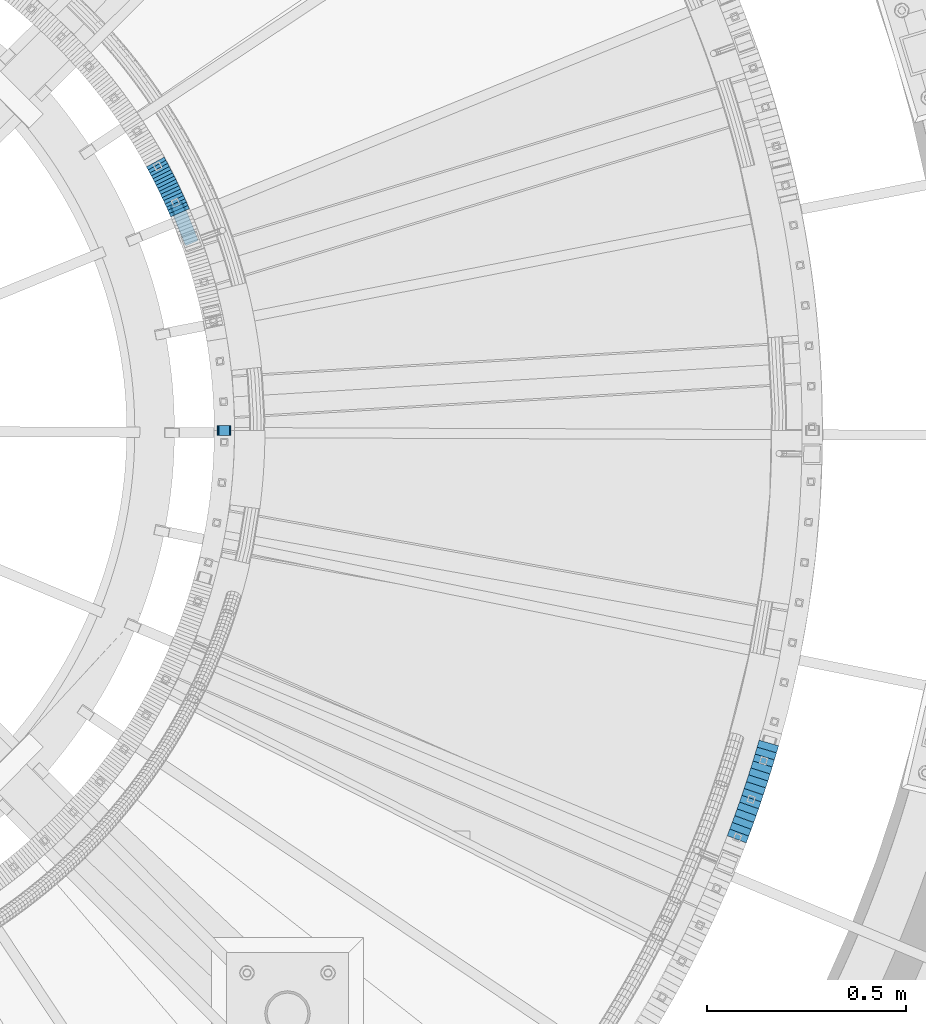
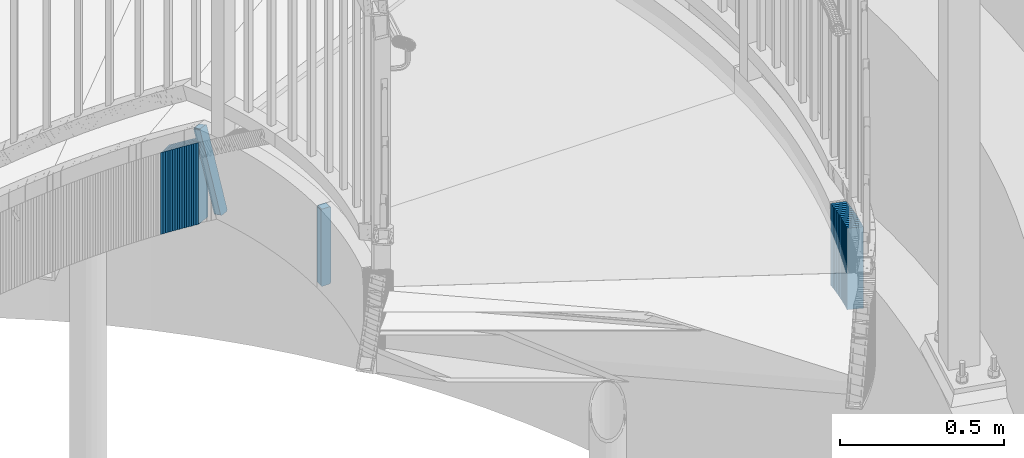
# One storey, part 909 of 975: 32 plates.
"""IFC2X3 building model written with IfcOpenShell, lengths in millimetres."""

from ifc_helpers import new_model, si_unit, frame, origin_with_axes, place, context, subcontext, project, spatial, faceted_brep, material, type_object, element, save


model = new_model("IFC2X3")

# Units and contexts
model_context = context("Model", 3, precision=1e-05, world=origin_with_axes())
body_context = subcontext(model_context, "Body", "Model", "MODEL_VIEW")
ifc_project = project(units=[si_unit("LENGTHUNIT", "METRE", prefix="MILLI"), si_unit("AREAUNIT", "SQUARE_METRE"), si_unit("VOLUMEUNIT", "CUBIC_METRE"), si_unit("MASSUNIT", "GRAM", prefix="KILO"), si_unit("TIMEUNIT", "SECOND"), si_unit("PLANEANGLEUNIT", "RADIAN"), si_unit("SOLIDANGLEUNIT", "STERADIAN"), si_unit("THERMODYNAMICTEMPERATUREUNIT", "DEGREE_CELSIUS"), si_unit("LUMINOUSINTENSITYUNIT", "LUMEN")], contexts=[model_context])

# Site, building, storey
site_placement = place(None, origin_with_axes())
site = spatial("IfcSite", under=ifc_project, at=site_placement, CompositionType="ELEMENT")
building_placement = place(site_placement, origin_with_axes())
building = spatial("IfcBuilding", under=site, at=building_placement, Name="Undefined", CompositionType="ELEMENT")
storey_placement = place(building_placement, origin_with_axes())
storey = spatial("IfcBuildingStorey", under=building, at=storey_placement, Name="Undefined", CompositionType="ELEMENT", Elevation=0.0)

# Plates
ifc_material = material(Name="STEEL/A36")
plate_type_1 = type_object("IfcPlateType", PredefinedType="NOTDEFINED")
plate_1_placement = place(storey_placement, frame((36031.1330134072, 3968.06101194895, 2176.46249923706), z_axis=(0.10972960292441, -0.250969635863121, -0.961755507453315), x_axis=(-0.916250635537138, -0.400605507797622, 0.0)))
element("IfcPlate", 1, at=plate_1_placement, inside=storey, type_object=plate_type_1, material=ifc_material, Name="PLATE", context=body_context, shape_type="Brep", body=[
    faceted_brep([(0.0621872350457124, -12.7000000000153, 6.41158689863494), (2.85260804046266, -12.7000000001062, 294.107694539662), (2.85260804049904, 12.6999999999061, 294.107694539656), (0.0621872350820922, 12.7000000000007, 6.41158689862766), (3.35528182036796, -12.700000000108, 296.522954064043), (3.35528182039707, 12.6999999999043, 296.522954064037), (4.74048874637083, -12.7000000001117, 298.564365651953), (4.74048874640721, 12.6999999999043, 298.564365651947), (6.79914975482097, -12.7000000001135, 299.923804636008), (6.79914975486463, 12.6999999999025, 299.923804636002), (9.22053660148231, -12.7000000001135, 300.396081290006), (9.22053660151869, 12.6999999999007, 300.396081290001), (31.4448763015389, -12.7000000001299, 300.332287296218), (31.444876301568, 12.6999999998861, 300.332287296212), (33.8835784619441, -12.7000000001299, 299.837738071908), (33.8835784619805, 12.6999999998807, 299.837738071903), (35.9449991467991, -12.7000000001335, 298.444040858553), (35.9449991468355, 12.6999999998843, 298.444040858547), (37.3125904683984, -12.7000000001353, 296.365209181976), (37.3125904684421, 12.6999999998825, 296.36520918197), (37.776347672625, -12.7000000001335, 293.920464529052), (37.7763476726614, 12.6999999998843, 293.920464529045), (34.9746749639598, -12.7000000000389, 6.28815088188219), (34.9746749639889, 12.6999999999753, 6.28815088187628), (34.4737031095356, -12.7000000000389, 3.8771689034578), (34.4737031095719, 12.6999999999789, 3.87716890345143), (33.0931838258039, -12.7000000000371, 1.83805796816011), (33.0931838258402, 12.6999999999789, 1.8380579681542), (31.0407233526712, -12.7000000000335, 0.477465117444694), (31.0407233527148, 12.6999999999807, 0.477465117438783), (28.6249762713633, -12.7000000000317, 9.22000253922306e-11), (28.6249762713996, 12.6999999999844, 8.62883098307066e-11), (6.41188847456942, -12.7000000000171, 2.35331754083745e-11), (6.41188847461308, 12.6999999999989, 1.7166712495964e-11), (3.96763090910827, -12.7000000000171, 0.489274374265619), (3.96763090914465, 12.6999999999989, 0.489274374259708), (1.90003873223759, -12.7000000000135, 1.88169925546742), (1.90003873227397, 12.7000000000007, 1.88169925546151), (0.527732379785448, -12.7000000000153, 3.96269895144985), (0.527732379829104, 12.7000000000007, 3.96269895144349)], [[[0, 1, 2, 3]], [[1, 4, 5, 2]], [[4, 6, 7, 5]], [[6, 8, 9, 7]], [[8, 10, 11, 9]], [[10, 12, 13, 11]], [[12, 14, 15, 13]], [[14, 16, 17, 15]], [[16, 18, 19, 17]], [[18, 20, 21, 19]], [[20, 22, 23, 21]], [[22, 24, 25, 23]], [[24, 26, 27, 25]], [[26, 28, 29, 27]], [[28, 30, 31, 29]], [[30, 32, 33, 31]], [[32, 34, 35, 33]], [[34, 36, 37, 35]], [[36, 38, 39, 37]], [[38, 0, 3, 39]], [[5, 7, 9, 11, 13, 15, 17, 19, 21, 23, 25, 27, 29, 31, 33, 35, 37, 39, 3, 2]], [[38, 36, 34, 32, 30, 28, 26, 24, 22, 20, 18, 16, 14, 12, 10, 8, 6, 4, 1, 0]]]),
])
plate_2_placement = place(storey_placement, frame((36148.4532372815, 3403.59999999999, 2176.46249923706), z_axis=(0.0, 0.0, -1.0), x_axis=(-0.999999999999998, 6.90000001668524e-08, 0.0)))
element("IfcPlate", 2, at=plate_2_placement, inside=storey, type_object=plate_type_1, material=ifc_material, Name="PLATE", context=body_context, shape_type="Brep", body=[
    faceted_brep([(-4.05850369133987e-06, -12.7000000000298, 6.34999584616526), (0.0, -12.6999999999998, 282.574987888336), (0.0, 12.6999999999998, 282.574987888336), (-4.05842729378492e-06, 12.7000000000335, 6.34999584617253), (0.483364961291954, -12.6999999999998, 285.005027647359), (0.483364961291954, 12.6999999999998, 285.005027647359), (1.85987191153254, -12.6999999999998, 287.065115881436), (1.85987191153254, 12.6999999999998, 287.065115881436), (3.919960145613, -12.6999999999998, 288.441622831675), (3.919960145613, 12.6999999999998, 288.441622831675), (6.34999990463257, -12.6999999999998, 288.924987792969), (6.34999990463257, 12.6999999999998, 288.924987792969), (28.5687317848206, -12.6999999999998, 288.924987792969), (28.5687317848206, 12.6999999999998, 288.924987792969), (30.9987715438401, -12.6999999999998, 288.441622831675), (30.9987715438401, 12.6999999999998, 288.441622831675), (33.0588597779206, -12.6999999999998, 287.065115881436), (33.0588597779206, 12.6999999999998, 287.065115881436), (34.4353667281612, -12.6999999999998, 285.005027647359), (34.4353667281612, 12.6999999999998, 285.005027647359), (34.9187316894531, -12.6999999999998, 282.574987888336), (34.9187316894531, 12.6999999999998, 282.574987888336), (34.9187276514203, -12.6999999999643, 6.35000394271628), (34.9187276514895, 12.7000000000917, 6.35000394272356), (34.4353638491048, -12.6999999999607, 3.91996294363889), (34.4353638491739, 12.7000000000917, 3.91996294364617), (33.0588597779206, -12.6999999999998, 1.85987191153299), (33.0588597779206, 12.6999999999998, 1.85987191153299), (30.9987715438401, -12.6999999999998, 0.483364961293773), (30.9987715438401, 12.6999999999998, 0.483364961293773), (28.5687317848206, -12.6999999999998, 0.0), (28.5687317848206, 12.6999999999998, 0.0), (6.34999990463257, -12.6999999999998, 0.0), (6.34999990463257, 12.6999999999998, 0.0), (3.919960145613, -12.6999999999998, 0.483364961293773), (3.919960145613, 12.6999999999998, 0.483364961293773), (1.85987191153254, -12.6999999999998, 1.85987191153299), (1.85987191153254, 12.6999999999998, 1.85987191153299), (0.483362067625421, -12.7000000000262, 3.91995733345902), (0.483362067694543, 12.7000000000298, 3.91995733346448)], [[[0, 1, 2, 3]], [[1, 4, 5, 2]], [[4, 6, 7, 5]], [[6, 8, 9, 7]], [[8, 10, 11, 9]], [[10, 12, 13, 11]], [[12, 14, 15, 13]], [[14, 16, 17, 15]], [[16, 18, 19, 17]], [[18, 20, 21, 19]], [[20, 22, 23, 21]], [[22, 24, 25, 23]], [[24, 26, 27, 25]], [[26, 28, 29, 27]], [[28, 30, 31, 29]], [[30, 32, 33, 31]], [[32, 34, 35, 33]], [[34, 36, 37, 35]], [[36, 38, 39, 37]], [[38, 0, 3, 39]], [[5, 7, 9, 11, 13, 15, 17, 19, 21, 23, 25, 27, 29, 31, 33, 35, 37, 39, 3, 2]], [[38, 36, 34, 32, 30, 28, 26, 24, 22, 20, 18, 16, 14, 12, 10, 8, 6, 4, 1, 0]]]),
])
plate_type_2 = type_object("IfcPlateType", PredefinedType="NOTDEFINED")
plate_3_placement = place(storey_placement, frame((37421.8742056828, 2396.18370517929, 1956.48750006771), z_axis=(-0.351123442136333, -0.936329177363566, 0.0), x_axis=(0.0, 0.0, 1.0)))
element("IfcPlate", 3, at=plate_3_placement, inside=storey, type_object=plate_type_2, material=ifc_material, Name="WALL", context=body_context, shape_type="Brep", body=[
    faceted_brep([(0.0, -25.3999999999724, -1.81898940354586e-11), (5.80000019073486, -25.3999999999614, 17.9424076079595), (5.80000019073486, 25.3999999999978, 17.9424076080322), (0.0, 25.3999999999869, 1.45519152283669e-11), (310.600006103516, -25.3999999999614, 17.9424076079595), (310.600006103516, 25.3999999999978, 17.9424076080322), (304.799987792969, -25.3999999999724, -1.81898940354586e-11), (304.799987792969, 25.3999999999869, 1.45519152283669e-11)], [[[0, 1, 2, 3]], [[1, 4, 5, 2]], [[4, 6, 7, 5]], [[6, 0, 3, 7]], [[5, 7, 3, 2]], [[6, 4, 1, 0]]]),
])
plate_4_placement = place(storey_placement, frame((37428.1205128094, 2413.10817970583, 1950.78750006771), z_axis=(-0.346222869900943, -0.938152292731598, 0.0), x_axis=(0.0, 0.0, 1.0)))
element("IfcPlate", 4, at=plate_4_placement, inside=storey, type_object=plate_type_2, material=ifc_material, Name="WALL", context=body_context, shape_type="Brep", body=[
    faceted_brep([(0.0, -25.3999999999724, -1.81898940354586e-11), (5.69999980926514, -25.4000000000633, 17.9075393677485), (5.69999980926514, 25.3999999999905, 17.9075393676903), (0.0, 25.3999999999869, 1.45519152283669e-11), (310.5, -25.4000000000633, 17.9075393677485), (310.5, 25.3999999999905, 17.9075393676903), (304.799987792969, -25.3999999999724, -1.81898940354586e-11), (304.799987792969, 25.3999999999869, 1.45519152283669e-11)], [[[0, 1, 2, 3]], [[1, 4, 5, 2]], [[4, 6, 7, 5]], [[6, 0, 3, 7]], [[5, 7, 3, 2]], [[6, 4, 1, 0]]]),
])
plate_5_placement = place(storey_placement, frame((37434.3205128088, 2429.90817970583, 1944.98750006771), z_axis=(-0.346222869900943, -0.938152292731598, 0.0), x_axis=(0.0, 0.0, 1.0)))
element("IfcPlate", 5, at=plate_5_placement, inside=storey, type_object=plate_type_2, material=ifc_material, Name="WALL", context=body_context, shape_type="Brep", body=[
    faceted_brep([(0.0, -25.3999999999724, -1.81898940354586e-11), (5.80000019073486, -25.3999999999905, 17.9067020416114), (5.80000019073486, 25.399999999976, 17.9067020416369), (0.0, 25.3999999999869, 1.45519152283669e-11), (310.600006103516, -25.3999999999905, 17.9067020416114), (310.600006103516, 25.399999999976, 17.9067020416369), (304.799987792969, -25.3999999999724, -1.81898940354586e-11), (304.799987792969, 25.3999999999869, 1.45519152283669e-11)], [[[0, 1, 2, 3]], [[1, 4, 5, 2]], [[4, 6, 7, 5]], [[6, 0, 3, 7]], [[5, 7, 3, 2]], [[6, 4, 1, 0]]]),
])
plate_6_placement = place(storey_placement, frame((37440.4276690588, 2447.10417273845, 1939.28750006771), z_axis=(-0.33456960089993, -0.942371042718133, 0.0), x_axis=(0.0, 0.0, 1.0)))
element("IfcPlate", 6, at=plate_6_placement, inside=storey, type_object=plate_type_2, material=ifc_material, Name="WALL", context=body_context, shape_type="Brep", body=[
    faceted_brep([(0.0, -25.3999999999724, -1.81898940354586e-11), (5.69999980926514, -25.3999999999896, 17.9334888457815), (5.69999980926514, 25.3999999999869, 17.9334888458907), (0.0, 25.3999999999869, 1.45519152283669e-11), (310.5, -25.3999999999896, 17.9334888457815), (310.5, 25.3999999999869, 17.9334888458907), (304.799987792969, -25.3999999999724, -1.81898940354586e-11), (304.799987792969, 25.3999999999869, 1.45519152283669e-11)], [[[0, 1, 2, 3]], [[1, 4, 5, 2]], [[4, 6, 7, 5]], [[6, 0, 3, 7]], [[5, 7, 3, 2]], [[6, 4, 1, 0]]]),
])
plate_7_placement = place(storey_placement, frame((37446.4433990456, 2464.14860960824, 1933.48750006771), z_axis=(-0.332820117839757, -0.942990333545965, 0.0), x_axis=(0.0, 0.0, 1.0)))
element("IfcPlate", 7, at=plate_7_placement, inside=storey, type_object=plate_type_2, material=ifc_material, Name="WALL", context=body_context, shape_type="Brep", body=[
    faceted_brep([(0.0, -25.3999999999724, -1.81898940354586e-11), (5.80000019073486, -25.4000000000196, 18.0313606262353), (5.80000019073486, 25.3999999999905, 18.0313606262353), (0.0, 25.3999999999869, 1.45519152283669e-11), (310.600006103516, -25.4000000000196, 18.0313606262353), (310.600006103516, 25.3999999999905, 18.0313606262353), (304.799987792969, -25.3999999999724, -1.81898940354586e-11), (304.799987792969, 25.3999999999869, 1.45519152283669e-11)], [[[0, 1, 2, 3]], [[1, 4, 5, 2]], [[4, 6, 7, 5]], [[6, 0, 3, 7]], [[5, 7, 3, 2]], [[6, 4, 1, 0]]]),
])
plate_8_placement = place(storey_placement, frame((37452.3308395669, 2481.40056465231, 1927.68750006771), z_axis=(-0.322900627911091, -0.946432873739402, 0.0), x_axis=(0.0, 0.0, 1.0)))
element("IfcPlate", 8, at=plate_8_placement, inside=storey, type_object=plate_type_2, material=ifc_material, Name="WALL", context=body_context, shape_type="Brep", body=[
    faceted_brep([(0.0, -25.3999999999724, -1.81898940354586e-11), (5.80000019073486, -25.399999999976, 17.9610691070338), (5.80000019073486, 25.4000000000269, 17.9610691070338), (0.0, 25.3999999999869, 1.45519152283669e-11), (310.600006103516, -25.399999999976, 17.9610691070338), (310.600006103516, 25.4000000000269, 17.9610691070338), (304.799987792969, -25.3999999999724, -1.81898940354586e-11), (304.799987792969, 25.3999999999869, 1.45519152283669e-11)], [[[0, 1, 2, 3]], [[1, 4, 5, 2]], [[4, 6, 7, 5]], [[6, 0, 3, 7]], [[5, 7, 3, 2]], [[6, 4, 1, 0]]]),
])
plate_9_placement = place(storey_placement, frame((37458.1454677345, 2498.54356608938, 1921.88750006771), z_axis=(-0.321207657948762, -0.947008785848934, 0.0), x_axis=(0.0, 0.0, 1.0)))
element("IfcPlate", 9, at=plate_9_placement, inside=storey, type_object=plate_type_2, material=ifc_material, Name="WALL", context=body_context, shape_type="Brep", body=[
    faceted_brep([(0.0, -25.3999999999724, -1.81898940354586e-11), (5.80000019073486, -25.4000000000378, 18.0623912811516), (5.80000019073486, 25.4000000000051, 18.0623912811207), (0.0, 25.3999999999869, 1.45519152283669e-11), (310.600006103516, -25.4000000000378, 18.0623912811516), (310.600006103516, 25.4000000000051, 18.0623912811207), (304.799987792969, -25.3999999999724, -1.81898940354586e-11), (304.799987792969, 25.3999999999869, 1.45519152283669e-11)], [[[0, 1, 2, 3]], [[1, 4, 5, 2]], [[4, 6, 7, 5]], [[6, 0, 3, 7]], [[5, 7, 3, 2]], [[6, 4, 1, 0]]]),
])
plate_10_placement = place(storey_placement, frame((37463.9019814032, 2515.91212084005, 1916.08750006771), z_axis=(-0.314571644145653, -0.949233733439505, 0.0), x_axis=(0.0, 0.0, 1.0)))
element("IfcPlate", 10, at=plate_10_placement, inside=storey, type_object=plate_type_2, material=ifc_material, Name="WALL", context=body_context, shape_type="Brep", body=[
    faceted_brep([(0.0, -25.3999999999724, -1.81898940354586e-11), (5.80000019073486, -25.3999999999614, 18.115739822355), (5.80000019073486, 25.3999999999833, 18.115739822395), (0.0, 25.3999999999869, 1.45519152283669e-11), (310.600006103516, -25.3999999999614, 18.115739822355), (310.600006103516, 25.3999999999833, 18.115739822395), (304.799987792969, -25.3999999999724, -1.81898940354586e-11), (304.799987792969, 25.3999999999869, 1.45519152283669e-11)], [[[0, 1, 2, 3]], [[1, 4, 5, 2]], [[4, 6, 7, 5]], [[6, 0, 3, 7]], [[5, 7, 3, 2]], [[6, 4, 1, 0]]]),
])
plate_11_placement = place(storey_placement, frame((37469.4714983436, 2533.22503032498, 1910.28750006771), z_axis=(-0.306189380956472, -0.951970620864684, 0.0), x_axis=(0.0, 0.0, 1.0)))
element("IfcPlate", 11, at=plate_11_placement, inside=storey, type_object=plate_type_2, material=ifc_material, Name="WALL", context=body_context, shape_type="Brep", body=[
    faceted_brep([(0.0, -25.3999999999724, -1.81898940354586e-11), (5.80000019073486, -25.399999999976, 17.9610691070338), (5.80000019073486, 25.4000000000269, 17.9610691070338), (0.0, 25.3999999999869, 1.45519152283669e-11), (310.600006103516, -25.399999999976, 17.9610691070338), (310.600006103516, 25.4000000000269, 17.9610691070338), (304.799987792969, -25.3999999999724, -1.81898940354586e-11), (304.799987792969, 25.3999999999869, 1.45519152283669e-11)], [[[0, 1, 2, 3]], [[1, 4, 5, 2]], [[4, 6, 7, 5]], [[6, 0, 3, 7]], [[5, 7, 3, 2]], [[6, 4, 1, 0]]]),
])
plate_12_placement = place(storey_placement, frame((37474.9975962966, 2550.60664323899, 1904.48750006771), z_axis=(-0.302976274105356, -0.952998099331387, 0.0), x_axis=(0.0, 0.0, 1.0)))
element("IfcPlate", 12, at=plate_12_placement, inside=storey, type_object=plate_type_2, material=ifc_material, Name="WALL", context=body_context, shape_type="Brep", body=[
    faceted_brep([(0.0, -25.3999999999724, -1.81898940354586e-11), (5.80000019073486, -25.4000000000015, 18.153236389162), (5.80000019073486, 25.4000000000233, 18.1532363891747), (0.0, 25.3999999999869, 1.45519152283669e-11), (310.600006103516, -25.4000000000015, 18.153236389162), (310.600006103516, 25.4000000000233, 18.1532363891747), (304.799987792969, -25.3999999999724, -1.81898940354586e-11), (304.799987792969, 25.3999999999869, 1.45519152283669e-11)], [[[0, 1, 2, 3]], [[1, 4, 5, 2]], [[4, 6, 7, 5]], [[6, 0, 3, 7]], [[5, 7, 3, 2]], [[6, 4, 1, 0]]]),
])
plate_13_placement = place(storey_placement, frame((37480.4377285068, 2568.03403636052, 1898.68750006771), z_axis=(-0.297960796877575, -0.954578107607796, 0.0), x_axis=(0.0, 0.0, 1.0)))
element("IfcPlate", 13, at=plate_13_placement, inside=storey, type_object=plate_type_2, material=ifc_material, Name="WALL", context=body_context, shape_type="Brep", body=[
    faceted_brep([(0.0, -25.3999999999724, -1.81898940354586e-11), (5.80000019073486, -25.3999999999614, 18.115739822355), (5.80000019073486, 25.3999999999833, 18.115739822395), (0.0, 25.3999999999869, 1.45519152283669e-11), (310.600006103516, -25.3999999999614, 18.115739822355), (310.600006103516, 25.3999999999833, 18.115739822395), (304.799987792969, -25.3999999999724, -1.81898940354586e-11), (304.799987792969, 25.3999999999869, 1.45519152283669e-11)], [[[0, 1, 2, 3]], [[1, 4, 5, 2]], [[4, 6, 7, 5]], [[6, 0, 3, 7]], [[5, 7, 3, 2]], [[6, 4, 1, 0]]]),
])
plate_14_placement = place(storey_placement, frame((37485.7892693309, 2585.60117905156, 1892.88750006771), z_axis=(-0.291380375972665, -0.956607273910265, 0.0), x_axis=(0.0, 0.0, 1.0)))
element("IfcPlate", 14, at=plate_14_placement, inside=storey, type_object=plate_type_2, material=ifc_material, Name="WALL", context=body_context, shape_type="Brep", body=[
    faceted_brep([(0.0, -25.3999999999724, -1.81898940354586e-11), (5.80000019073486, -25.400000000016, 18.1892833709626), (5.80000019073486, 25.4000000000087, 18.189283370979), (0.0, 25.3999999999869, 1.45519152283669e-11), (310.600006103516, -25.400000000016, 18.1892833709626), (310.600006103516, 25.4000000000087, 18.189283370979), (304.799987792969, -25.3999999999724, -1.81898940354586e-11), (304.799987792969, 25.3999999999869, 1.45519152283669e-11)], [[[0, 1, 2, 3]], [[1, 4, 5, 2]], [[4, 6, 7, 5]], [[6, 0, 3, 7]], [[5, 7, 3, 2]], [[6, 4, 1, 0]]]),
])
plate_15_placement = place(storey_placement, frame((37491.0279176622, 2603.12927163371, 1886.98750006771), z_axis=(-0.286337360928148, -0.958128861759578, 0.0), x_axis=(0.0, 0.0, 1.0)))
element("IfcPlate", 15, at=plate_15_placement, inside=storey, type_object=plate_type_2, material=ifc_material, Name="WALL", context=body_context, shape_type="Brep", body=[
    faceted_brep([(0.0, -25.3999999999724, -1.81898940354586e-11), (5.90000009536743, -25.4000000000233, 18.1617736816479), (5.90000009536743, 25.4000000000451, 18.1617736816097), (0.0, 25.3999999999869, 1.45519152283669e-11), (310.700012207032, -25.4000000000233, 18.1617736816479), (310.700012207032, 25.4000000000451, 18.1617736816097), (304.799987792969, -25.3999999999724, -1.81898940354586e-11), (304.799987792969, 25.3999999999869, 1.45519152283669e-11)], [[[0, 1, 2, 3]], [[1, 4, 5, 2]], [[4, 6, 7, 5]], [[6, 0, 3, 7]], [[5, 7, 3, 2]], [[6, 4, 1, 0]]]),
])
plate_16_placement = place(storey_placement, frame((37496.1770046651, 2620.79559167065, 1881.18750006771), z_axis=(-0.27978932797828, -0.960061420925486, 0.0), x_axis=(0.0, 0.0, 1.0)))
element("IfcPlate", 16, at=plate_16_placement, inside=storey, type_object=plate_type_2, material=ifc_material, Name="WALL", context=body_context, shape_type="Brep", body=[
    faceted_brep([(0.0, -25.3999999999724, -1.81898940354586e-11), (5.80000019073486, -25.400000000016, 18.2280006408655), (5.80000019073486, 25.4000000000378, 18.2280006408691), (0.0, 25.3999999999869, 1.45519152283669e-11), (310.600006103516, -25.400000000016, 18.2280006408655), (310.600006103516, 25.4000000000378, 18.2280006408691), (304.799987792969, -25.3999999999724, -1.81898940354586e-11), (304.799987792969, 25.3999999999869, 1.45519152283669e-11)], [[[0, 1, 2, 3]], [[1, 4, 5, 2]], [[4, 6, 7, 5]], [[6, 0, 3, 7]], [[5, 7, 3, 2]], [[6, 4, 1, 0]]]),
])
plate_type_3 = type_object("IfcPlateType", PredefinedType="NOTDEFINED")
for number, where, z_axis, x_axis, name in (
    (17, (36016.7730645843, 3957.95044576601, 2127.80000000134), (0.397917609160395, -0.917421155369809, 0.0), (0.0, 0.0, -1.0), "WALL"),
    (18, (36013.1730645911, 3966.25044576613, 2122.00000000133), (0.397917609160395, -0.917421155369809, 0.0), (0.0, 0.0, -1.0), "WALL"),
):
    element("IfcPlate", number, at=place(storey_placement, frame(where, z_axis=z_axis, x_axis=x_axis)), inside=storey, type_object=plate_type_3, material=ifc_material, Name=name, context=body_context, shape_type="Brep", body=[
        faceted_brep([(0.0, -25.3999999999724, -1.81898940354586e-11), (-5.80000019073486, -25.3999999999869, 9.05207157135192), (-5.80000019073486, 25.3999999999796, 9.05207157134646), (0.0, 25.3999999999869, 1.45519152283669e-11), (299.0, -25.3999999999869, 9.05207157135192), (299.0, 25.3999999999796, 9.05207157134646), (304.799987792969, -25.3999999999724, -1.81898940354586e-11), (304.799987792969, 25.3999999999869, 1.45519152283669e-11)], [[[0, 1, 2, 3]], [[1, 4, 5, 2]], [[4, 6, 7, 5]], [[6, 0, 3, 7]], [[5, 7, 3, 2]], [[6, 4, 1, 0]]]),
    ])
plate_17_placement = place(storey_placement, frame((36009.5762892473, 3974.31570860004, 2116.20000000132), z_axis=(0.40715922988212, -0.913357192735569, 0.0), x_axis=(0.0, 0.0, -1.0)))
element("IfcPlate", 19, at=plate_17_placement, inside=storey, type_object=plate_type_3, material=ifc_material, Name="WALL", context=body_context, shape_type="Brep", body=[
    faceted_brep([(0.0, -25.3999999999724, -1.81898940354586e-11), (-5.80000019073486, -25.4000000000742, 9.08735370631803), (-5.80000019073486, 25.4000000000306, 9.08735370637442), (0.0, 25.3999999999869, 1.45519152283669e-11), (299.0, -25.4000000000742, 9.08735370631803), (299.0, 25.4000000000306, 9.08735370637442), (304.799987792969, -25.3999999999724, -1.81898940354586e-11), (304.799987792969, 25.3999999999869, 1.45519152283669e-11)], [[[0, 1, 2, 3]], [[1, 4, 5, 2]], [[4, 6, 7, 5]], [[6, 0, 3, 7]], [[5, 7, 3, 2]], [[6, 4, 1, 0]]]),
])
plate_18_placement = place(storey_placement, frame((36005.9298725296, 3982.17784331386, 2110.40000000131), z_axis=(0.420461012783948, -0.907310606533781, 0.0), x_axis=(0.0, 0.0, -1.0)))
element("IfcPlate", 20, at=plate_18_placement, inside=storey, type_object=plate_type_3, material=ifc_material, Name="WALL", context=body_context, shape_type="Brep", body=[
    faceted_brep([(0.0, -25.3999999999724, -1.81898940354586e-11), (-5.80000019073486, -25.3999999999869, 9.03769874573663), (-5.80000019073486, 25.4000000000015, 9.03769874572754), (0.0, 25.3999999999869, 1.45519152283669e-11), (299.0, -25.3999999999869, 9.03769874573663), (299.0, 25.4000000000015, 9.03769874572754), (304.799987792969, -25.3999999999724, -1.81898940354586e-11), (304.799987792969, 25.3999999999869, 1.45519152283669e-11)], [[[0, 1, 2, 3]], [[1, 4, 5, 2]], [[4, 6, 7, 5]], [[6, 0, 3, 7]], [[5, 7, 3, 2]], [[6, 4, 1, 0]]]),
])
plate_19_placement = place(storey_placement, frame((36002.1233335116, 3990.61081581323, 2104.6000000013), z_axis=(0.411288867158, -0.911505056350149, 0.0), x_axis=(0.0, 0.0, -1.0)))
element("IfcPlate", 21, at=plate_19_placement, inside=storey, type_object=plate_type_3, material=ifc_material, Name="WALL", context=body_context, shape_type="Brep", body=[
    faceted_brep([(0.0, -25.3999999999724, -1.81898940354586e-11), (-5.80000019073486, -25.3999999999578, 8.99610996247975), (-5.80000019073486, 25.3999999999796, 8.99610996245065), (0.0, 25.3999999999869, 1.45519152283669e-11), (299.0, -25.3999999999578, 8.99610996247975), (299.0, 25.3999999999796, 8.99610996245065), (304.799987792969, -25.3999999999724, -1.81898940354586e-11), (304.799987792969, 25.3999999999869, 1.45519152283669e-11)], [[[0, 1, 2, 3]], [[1, 4, 5, 2]], [[4, 6, 7, 5]], [[6, 0, 3, 7]], [[5, 7, 3, 2]], [[6, 4, 1, 0]]]),
])
plate_20_placement = place(storey_placement, frame((35998.4377367194, 3998.34809959944, 2098.8000000013), z_axis=(0.429506040944259, -0.903063984882793, 0.0), x_axis=(0.0, 0.0, -1.0)))
element("IfcPlate", 22, at=plate_20_placement, inside=storey, type_object=plate_type_3, material=ifc_material, Name="WALL", context=body_context, shape_type="Brep", body=[
    faceted_brep([(0.0, -25.3999999999724, -1.81898940354586e-11), (-5.80000019073486, -25.4000000000888, 9.08019828791839), (-5.80000019073486, 25.4000000000597, 9.08019828800025), (0.0, 25.3999999999869, 1.45519152283669e-11), (299.0, -25.4000000000888, 9.08019828791839), (299.0, 25.4000000000597, 9.08019828800025), (304.799987792969, -25.3999999999724, -1.81898940354586e-11), (304.799987792969, 25.3999999999869, 1.45519152283669e-11)], [[[0, 1, 2, 3]], [[1, 4, 5, 2]], [[4, 6, 7, 5]], [[6, 0, 3, 7]], [[5, 7, 3, 2]], [[6, 4, 1, 0]]]),
])
plate_21_placement = place(storey_placement, frame((35994.5803155313, 4006.56965967738, 2093.0000000013), z_axis=(0.424720211576408, -0.905324661035195, -3.22928826790303e-10), x_axis=(0.0, 0.0, -1.0)))
element("IfcPlate", 23, at=plate_21_placement, inside=storey, type_object=plate_type_3, material=ifc_material, Name="WALL", context=body_context, shape_type="Brep", body=[
    faceted_brep([(0.0, -25.3999999999724, -1.81898940354586e-11), (-5.80000019073486, -25.4000000000742, 8.94706630702785), (-5.80000019073486, 25.4000000000306, 8.9470663070897), (0.0, 25.3999999999869, 1.45519152283669e-11), (299.0, -25.4000000000742, 8.94706630702785), (299.0, 25.4000000000306, 8.9470663070897), (304.799987792969, -25.3999999999724, -1.81898940354586e-11), (304.799987792969, 25.3999999999869, 1.45519152283669e-11)], [[[0, 1, 2, 3]], [[1, 4, 5, 2]], [[4, 6, 7, 5]], [[6, 0, 3, 7]], [[5, 7, 3, 2]], [[6, 4, 1, 0]]]),
])
plate_22_placement = place(storey_placement, frame((35990.7901195219, 4014.43863632053, 2087.20000000129), z_axis=(0.433815618951114, -0.901001669673293, -6.19365891907365e-11), x_axis=(0.0, 0.0, -1.0)))
element("IfcPlate", 24, at=plate_22_placement, inside=storey, type_object=plate_type_3, material=ifc_material, Name="WALL", context=body_context, shape_type="Brep", body=[
    faceted_brep([(0.0, -25.3999999999724, -1.81898940354586e-11), (-5.80000019073486, -25.3999999999796, 8.98721313478018), (-5.80000019073486, 25.399999999936, 8.98721313473106), (0.0, 25.3999999999869, 1.45519152283669e-11), (299.0, -25.3999999999796, 8.98721313478018), (299.0, 25.399999999936, 8.98721313473106), (304.799987792969, -25.3999999999724, -1.81898940354586e-11), (304.799987792969, 25.3999999999869, 1.45519152283669e-11)], [[[0, 1, 2, 3]], [[1, 4, 5, 2]], [[4, 6, 7, 5]], [[6, 0, 3, 7]], [[5, 7, 3, 2]], [[6, 4, 1, 0]]]),
])
plate_23_placement = place(storey_placement, frame((35986.9011565563, 4022.3109331156, 2081.50000000129), z_axis=(0.442780311978212, -0.896630132955879, 0.0), x_axis=(0.0, 0.0, -1.0)))
element("IfcPlate", 25, at=plate_23_placement, inside=storey, type_object=plate_type_3, material=ifc_material, Name="WALL", context=body_context, shape_type="Brep", body=[
    faceted_brep([(0.0, -25.3999999999724, -1.81898940354586e-11), (-5.69999980926514, -25.4000000000306, 9.03382492064338), (-5.69999980926514, 25.4000000000015, 9.03382492065066), (0.0, 25.3999999999869, 1.45519152283669e-11), (299.100006103516, -25.4000000000306, 9.03382492064338), (299.100006103516, 25.4000000000015, 9.03382492065066), (304.799987792969, -25.3999999999724, -1.81898940354586e-11), (304.799987792969, 25.3999999999869, 1.45519152283669e-11)], [[[0, 1, 2, 3]], [[1, 4, 5, 2]], [[4, 6, 7, 5]], [[6, 0, 3, 7]], [[5, 7, 3, 2]], [[6, 4, 1, 0]]]),
])
plate_24_placement = place(storey_placement, frame((35982.9571112699, 4030.19832772424, 2075.70000000128), z_axis=(0.447213595270113, -0.894427191114838, 4.34894445788813e-10), x_axis=(0.0, 0.0, -1.0)))
element("IfcPlate", 26, at=plate_24_placement, inside=storey, type_object=plate_type_3, material=ifc_material, Name="WALL", context=body_context, shape_type="Brep", body=[
    faceted_brep([(0.0, -25.3999999999724, -1.81898940354586e-11), (-5.80000019073486, -25.3999999999287, 8.93756103519445), (-5.80000019073486, 25.399999999936, 8.93756103512169), (0.0, 25.3999999999869, 1.45519152283669e-11), (299.0, -25.3999999999287, 8.93756103519445), (299.0, 25.399999999936, 8.93756103512169), (304.799987792969, -25.3999999999724, -1.81898940354586e-11), (304.799987792969, 25.3999999999869, 1.45519152283669e-11)], [[[0, 1, 2, 3]], [[1, 4, 5, 2]], [[4, 6, 7, 5]], [[6, 0, 3, 7]], [[5, 7, 3, 2]], [[6, 4, 1, 0]]]),
])
plate_25_placement = place(storey_placement, frame((35978.91334302, 4038.18655334924, 2069.90000000126), z_axis=(0.451614161035454, -0.892213343070055, 0.0), x_axis=(0.0, 0.0, -1.0)))
element("IfcPlate", 27, at=plate_25_placement, inside=storey, type_object=plate_type_3, material=ifc_material, Name="WALL", context=body_context, shape_type="Brep", body=[
    faceted_brep([(0.0, -25.3999999999724, -1.81898940354586e-11), (-5.80000019073486, -25.4000000000888, 9.08019828791839), (-5.80000019073486, 25.4000000000597, 9.08019828800025), (0.0, 25.3999999999869, 1.45519152283669e-11), (299.0, -25.4000000000888, 9.08019828791839), (299.0, 25.4000000000597, 9.08019828800025), (304.799987792969, -25.3999999999724, -1.81898940354586e-11), (304.799987792969, 25.3999999999869, 1.45519152283669e-11)], [[[0, 1, 2, 3]], [[1, 4, 5, 2]], [[4, 6, 7, 5]], [[6, 0, 3, 7]], [[5, 7, 3, 2]], [[6, 4, 1, 0]]]),
])
plate_26_placement = place(storey_placement, frame((35974.9147701177, 4046.08373440361, 2064.20000000125), z_axis=(0.451725143138006, -0.892157158272548, 0.0), x_axis=(0.0, 0.0, -1.0)))
element("IfcPlate", 28, at=plate_26_placement, inside=storey, type_object=plate_type_3, material=ifc_material, Name="WALL", context=body_context, shape_type="Brep", body=[
    faceted_brep([(0.0, -25.3999999999724, -1.81898940354586e-11), (-5.69999980926514, -25.4000000000669, 8.85494232174278), (-5.69999980926514, 25.4000000000742, 8.85494232181918), (0.0, 25.3999999999869, 1.45519152283669e-11), (299.100006103516, -25.4000000000669, 8.85494232174278), (299.100006103516, 25.4000000000742, 8.85494232181918), (304.799987792969, -25.3999999999724, -1.81898940354586e-11), (304.799987792969, 25.3999999999869, 1.45519152283669e-11)], [[[0, 1, 2, 3]], [[1, 4, 5, 2]], [[4, 6, 7, 5]], [[6, 0, 3, 7]], [[5, 7, 3, 2]], [[6, 4, 1, 0]]]),
])
plate_27_placement = place(storey_placement, frame((35970.8864552113, 4053.75077200661, 2058.40000000124), z_axis=(0.464833898931123, -0.885397902868812, 0.0), x_axis=(0.0, 0.0, -1.0)))
element("IfcPlate", 29, at=plate_27_placement, inside=storey, type_object=plate_type_3, material=ifc_material, Name="WALL", context=body_context, shape_type="Brep", body=[
    faceted_brep([(0.0, -25.3999999999724, -1.81898940354586e-11), (-5.80000019073486, -25.3999999999869, 9.03769874573663), (-5.80000019073486, 25.4000000000015, 9.03769874572754), (0.0, 25.3999999999869, 1.45519152283669e-11), (299.0, -25.3999999999869, 9.03769874573663), (299.0, 25.4000000000015, 9.03769874572754), (304.799987792969, -25.3999999999724, -1.81898940354586e-11), (304.799987792969, 25.3999999999869, 1.45519152283669e-11)], [[[0, 1, 2, 3]], [[1, 4, 5, 2]], [[4, 6, 7, 5]], [[6, 0, 3, 7]], [[5, 7, 3, 2]], [[6, 4, 1, 0]]]),
])
plate_28_placement = place(storey_placement, frame((35966.7480994104, 4061.53409195099, 2052.70000000123), z_axis=(0.469427602090115, -0.882970965771766, -1.18944626592565e-10), x_axis=(0.0, 0.0, -1.0)))
element("IfcPlate", 30, at=plate_28_placement, inside=storey, type_object=plate_type_3, material=ifc_material, Name="WALL", context=body_context, shape_type="Brep", body=[
    faceted_brep([(0.0, -25.3999999999724, -1.81898940354586e-11), (-5.69999980926514, -25.4000000000451, 8.94986057279493), (-5.69999980926514, 25.3999999999942, 8.94986057280948), (0.0, 25.3999999999869, 1.45519152283669e-11), (299.100006103516, -25.4000000000451, 8.94986057279493), (299.100006103516, 25.3999999999942, 8.94986057280948), (304.799987792969, -25.3999999999724, -1.81898940354586e-11), (304.799987792969, 25.3999999999869, 1.45519152283669e-11)], [[[0, 1, 2, 3]], [[1, 4, 5, 2]], [[4, 6, 7, 5]], [[6, 0, 3, 7]], [[5, 7, 3, 2]], [[6, 4, 1, 0]]]),
])
plate_29_placement = place(storey_placement, frame((35962.611596, 4069.2154175357, 2047.00000000123), z_axis=(0.474099822975382, -0.880471099954287, 0.0), x_axis=(0.0, 0.0, -1.0)))
element("IfcPlate", 31, at=plate_29_placement, inside=storey, type_object=plate_type_3, material=ifc_material, Name="WALL", context=body_context, shape_type="Brep", body=[
    faceted_brep([(0.0, -25.3999999999724, -1.81898940354586e-11), (-5.69999980926491, -25.3999999999869, 8.86002254486812), (-5.69999980926491, 25.3999999999942, 8.86002254485538), (0.0, 25.3999999999869, 1.45519152283669e-11), (299.100006103516, -25.3999999999869, 8.86002254486812), (299.100006103516, 25.3999999999942, 8.86002254485538), (304.799987792969, -25.3999999999724, -1.81898940354586e-11), (304.799987792969, 25.3999999999869, 1.45519152283669e-11)], [[[0, 1, 2, 3]], [[1, 4, 5, 2]], [[4, 6, 7, 5]], [[6, 0, 3, 7]], [[5, 7, 3, 2]], [[6, 4, 1, 0]]]),
])
plate_30_placement = place(storey_placement, frame((35958.3662309426, 4077.01449944905, 2041.20000000122), z_axis=(0.478072975651703, -0.87832011815256, 2.40087956626667e-10), x_axis=(0.0, 0.0, -1.0)))
element("IfcPlate", 32, at=plate_30_placement, inside=storey, type_object=plate_type_3, material=ifc_material, Name="WALL", context=body_context, shape_type="Brep", body=[
    faceted_brep([(0.0, -25.3999999999724, -1.81898940354586e-11), (-5.80000019073486, -25.3999999999796, 8.98721313478018), (-5.80000019073486, 25.399999999936, 8.98721313473106), (0.0, 25.3999999999869, 1.45519152283669e-11), (299.0, -25.3999999999796, 8.98721313478018), (299.0, 25.399999999936, 8.98721313473106), (304.799987792969, -25.3999999999724, -1.81898940354586e-11), (304.799987792969, 25.3999999999869, 1.45519152283669e-11)], [[[0, 1, 2, 3]], [[1, 4, 5, 2]], [[4, 6, 7, 5]], [[6, 0, 3, 7]], [[5, 7, 3, 2]], [[6, 4, 1, 0]]]),
])

save(model, "model.ifc")
